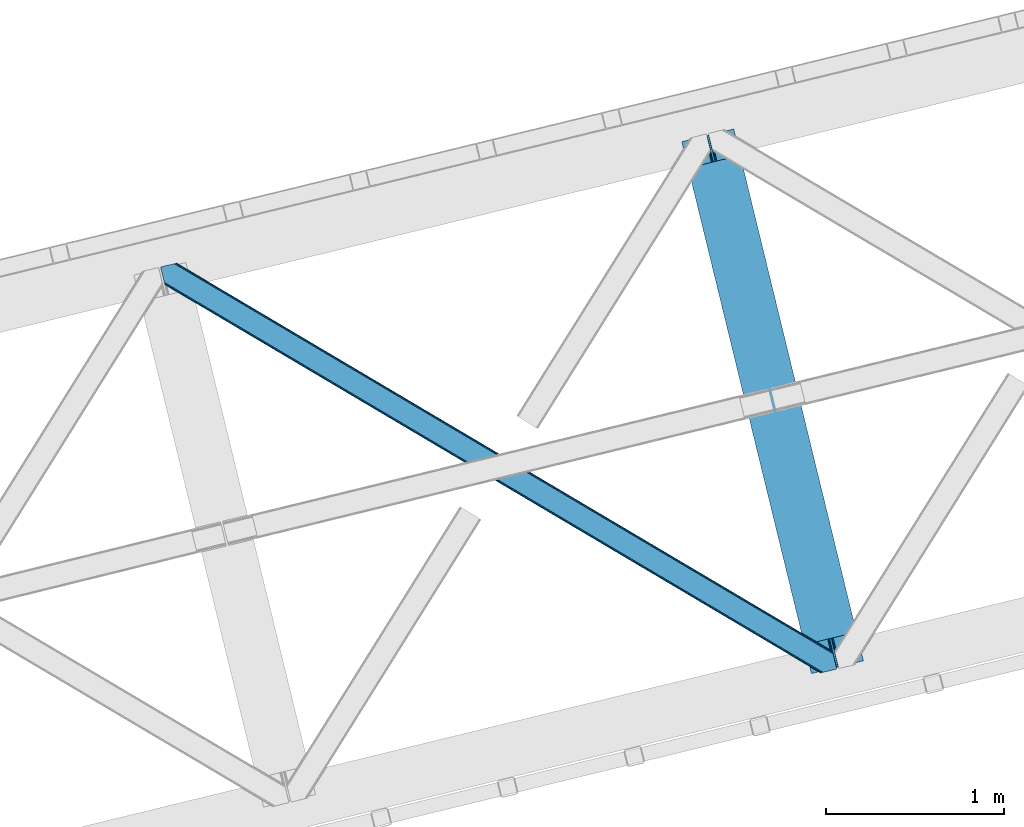
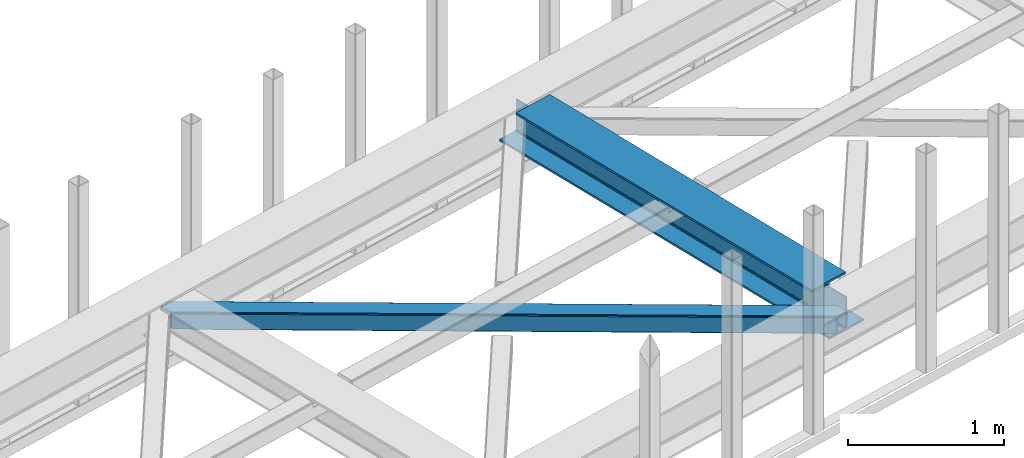
# One storey, part 41 of 67: 1 beam, 1 member.
"""IFC4 building model written with IfcOpenShell, lengths in millimetres."""

from ifc_helpers import new_model, entity, si_unit, converted_unit, derived_unit, direction, frame, origin, place, context, subcontext, project, spatial, triangles, polygons, material, type_object, element, save


model = new_model("IFC4")

# Units and contexts
model_context = context("Model", 3, precision=0.01, world=origin(), true_north=direction((6.12303176911189e-17, 1.0)))
plan_context = context("Plan", 3, precision=0.01, world=origin(), true_north=direction((6.12303176911189e-17, 1.0)))
body_context = subcontext(model_context, "Body", "Model", "MODEL_VIEW")
ifc_project = project(units=[si_unit("LENGTHUNIT", "METRE", prefix="MILLI"), si_unit("AREAUNIT", "SQUARE_METRE"), si_unit("VOLUMEUNIT", "CUBIC_METRE"), converted_unit("PLANEANGLEUNIT", "DEGREE", entity("IfcRatioMeasure", 0.0174532925199433), si_unit("PLANEANGLEUNIT", "RADIAN"), dimensions=[0, 0, 0, 0, 0, 0, 0]), si_unit("MASSUNIT", "GRAM", prefix="KILO"), derived_unit("MASSDENSITYUNIT", [(si_unit("MASSUNIT", "GRAM", prefix="KILO"), 1), (si_unit("LENGTHUNIT", "METRE"), -3)]), derived_unit("MOMENTOFINERTIAUNIT", [(si_unit("LENGTHUNIT", "METRE"), 4)]), si_unit("TIMEUNIT", "SECOND"), si_unit("FREQUENCYUNIT", "HERTZ"), si_unit("THERMODYNAMICTEMPERATUREUNIT", "DEGREE_CELSIUS"), derived_unit("THERMALTRANSMITTANCEUNIT", [(si_unit("MASSUNIT", "GRAM", prefix="KILO"), 1), (si_unit("THERMODYNAMICTEMPERATUREUNIT", "KELVIN"), -1), (si_unit("TIMEUNIT", "SECOND"), -3)]), derived_unit("VOLUMETRICFLOWRATEUNIT", [(si_unit("LENGTHUNIT", "METRE"), 3), (si_unit("TIMEUNIT", "SECOND"), -1)]), derived_unit("MASSFLOWRATEUNIT", [(si_unit("MASSUNIT", "GRAM", prefix="KILO"), 1), (si_unit("TIMEUNIT", "SECOND"), -1)]), derived_unit("ROTATIONALFREQUENCYUNIT", [(si_unit("TIMEUNIT", "SECOND"), -1)]), si_unit("ELECTRICCURRENTUNIT", "AMPERE"), si_unit("ELECTRICVOLTAGEUNIT", "VOLT"), si_unit("POWERUNIT", "WATT"), si_unit("FORCEUNIT", "NEWTON", prefix="KILO"), si_unit("ILLUMINANCEUNIT", "LUX"), si_unit("LUMINOUSFLUXUNIT", "LUMEN"), si_unit("LUMINOUSINTENSITYUNIT", "CANDELA"), derived_unit("USERDEFINED", [(si_unit("MASSUNIT", "GRAM", prefix="KILO"), -1), (si_unit("LENGTHUNIT", "METRE"), -2), (si_unit("TIMEUNIT", "SECOND"), 3), (si_unit("LUMINOUSFLUXUNIT", "LUMEN"), 1)]), derived_unit("LINEARVELOCITYUNIT", [(si_unit("LENGTHUNIT", "METRE"), 1), (si_unit("TIMEUNIT", "SECOND"), -1)]), si_unit("PRESSUREUNIT", "PASCAL"), derived_unit("USERDEFINED", [(si_unit("LENGTHUNIT", "METRE"), -2), (si_unit("MASSUNIT", "GRAM", prefix="KILO"), 1), (si_unit("TIMEUNIT", "SECOND"), -2)]), derived_unit("LINEARFORCEUNIT", [(si_unit("MASSUNIT", "GRAM", prefix="KILO"), 1), (si_unit("LENGTHUNIT", "METRE"), 1), (si_unit("TIMEUNIT", "SECOND"), -2), (si_unit("LENGTHUNIT", "METRE"), -1)]), derived_unit("PLANARFORCEUNIT", [(si_unit("MASSUNIT", "GRAM", prefix="KILO"), 1), (si_unit("LENGTHUNIT", "METRE"), 1), (si_unit("TIMEUNIT", "SECOND"), -2), (si_unit("LENGTHUNIT", "METRE"), -2)])], contexts=[model_context, plan_context])

# Site, building, storey
site_placement = place(None, origin())
site = spatial("IfcSite", under=ifc_project, at=site_placement, CompositionType="ELEMENT")
building_placement = place(site_placement, origin())
building = spatial("IfcBuilding", under=site, at=building_placement, CompositionType="ELEMENT")
storey_placement = place(building_placement, frame((0.0, 0.0, 19800.0)))
storey = spatial("IfcBuildingStorey", under=building, at=storey_placement, CompositionType="ELEMENT", Elevation=19800.0)

# Beam
ifc_material = material(Name="Metal painted (White)")
beam_type = type_object("IfcBeamType", PredefinedType="BEAM")
beam_placement = place(storey_placement, frame((-24164.8206423589, 11904.4985223094, 3807.02022389142)))
element("IfcBeam", 1, at=beam_placement, inside=storey, type_object=beam_type, material=ifc_material, ObjectType="Steel Beam", PredefinedType="BEAM", context=body_context, shape_type="Tessellation", body=[
    polygons([(1018.16648378329, 71.0478278971021, 15.5000000000008), (1018.16648378329, 71.0478278971, 0.0), (291.465617442446, 3052.25531830421, 0.0), (291.465617442446, 3052.25531830421, 15.5000000000008), (894.779372399325, 40.970914087327, 15.5000000000008), (168.078506058478, 3022.17840449444, 15.5000000000008), (888.087028625371, 39.3395844888221, 16.8701684147984), (161.38616228452, 3020.54707489593, 16.8701684147984), (882.413533524746, 37.9566100336519, 20.7720779386478), (155.712667183895, 3019.16410044076, 20.7720779386478), (878.622625296176, 37.0325360459184, 26.6116982174338), (151.921758955325, 3018.24002645303, 26.6116982174338), (877.291435352779, 36.7080444135007, 33.500000000001), (150.590569011932, 3017.91553482061, 33.500000000001), (140.875048430518, 3015.54727389071, 33.500000000001), (140.875048430514, 3015.54727389071, 259.000000000002), (150.590569011932, 3017.91553482061, 259.000000000002), (0.0, 2981.20749040711, 0.0), (4.33146851719357e-12, 2981.20749040711, 15.4999999999965), (123.387111383972, 3011.28440421689, 15.5000000000008), (130.079455157926, 3012.91573381539, 16.8701684147984), (135.752950258551, 3014.29870827056, 20.7720779386434), (139.543858487122, 3015.22278225829, 26.6116982174294), (877.291435352779, 36.7080444135007, 259.000000000002), (867.575914771365, 34.3397834835992, 259.000000000002), (867.575914771365, 34.3397834835992, 33.500000000001), (866.244724827968, 34.0152918511837, 26.6116982174294), (862.453816599397, 33.0912178634502, 20.7720779386434), (856.780321498777, 31.7082434082778, 16.8701684147984), (850.087977724819, 30.0769138097708, 15.5000000000008), (726.700866340851, 0.0, 15.4999999999965), (726.700866340851, 0.0, 0.0), (838.124523615916, 197.385937999183, 259.069791973884), (186.469722099967, 2870.72539801218, 259.000000000002), (186.69311520182, 2869.80895360721, 259.617303331124), (186.70550404545, 2869.75812937344, 266.500003008253), (837.979344808143, 197.981416001704, 266.500002998871), (837.979694928899, 197.97997969697, 260.000004007589), (828.499586345872, 194.645865944434, 259.006343171919), (828.276216326107, 195.562317481914, 259.617303331124), (828.263827482477, 195.613141715687, 266.500003008253), (176.98998671978, 2867.38985508742, 266.500002998871), (176.989636599032, 2867.39129139215, 260.000004007589), (176.844830940687, 2867.98534020594, 259.07612046749), (176.754201518552, 2868.35713708228, 259.000000000002), (839.31083267807, 198.30468544639, 273.388305639783), (843.101109266757, 199.231350618303, 279.227924098781), (848.774180214296, 200.616065081981, 283.129832400615), (855.46637189543, 202.248018612794, 284.500000377228), (978.853400583269, 232.325271667903, 284.500000138971), (978.851730776613, 232.332121736637, 299.999995328161), (687.386308679343, 161.283492472596, 299.999995890962), (687.387978485999, 161.276642403863, 284.500000701776), (810.775007173847, 191.353895458974, 284.500000463519), (817.467494069986, 192.984637925553, 283.129832461069), (823.141405718746, 194.365903570079, 279.227924137322), (826.932940505738, 195.287407219375, 273.388305663684), (175.658498849857, 2867.06658564273, 273.388305639788), (171.868222261165, 2866.13992047082, 279.227924098781), (166.195151313635, 2864.75520600714, 283.129832400619), (159.502959632502, 2863.12325247633, 284.500000377228), (36.1159309446533, 2833.04599942122, 284.500000138971), (36.1176007513094, 2833.03914935249, 299.999995328161), (327.58302284858, 2904.08777861653, 299.999995890962), (327.581353041924, 2904.09462868526, 284.500000701776), (204.194324354084, 2874.01737563015, 284.500000463519), (197.501837457945, 2872.38663316357, 283.129832461065), (191.827925809176, 2871.00536751904, 279.227924137322), (188.036391022189, 2870.08386386975, 273.388305663684)], [[[1, 2, 3, 4]], [[5, 1, 4, 6]], [[7, 5, 6, 8]], [[9, 7, 8, 10]], [[11, 9, 10, 12]], [[13, 11, 12, 14]], [[15, 16, 17, 14, 12, 10, 8, 6, 4, 3, 18, 19, 20, 21, 22, 23]], [[13, 24, 25, 26, 27, 28, 29, 30, 31, 32, 2, 1, 5, 7, 9, 11]], [[2, 32, 18, 3]], [[32, 31, 19, 18]], [[31, 30, 20, 19]], [[27, 26, 15, 23]], [[28, 27, 23, 22]], [[29, 28, 22, 21]], [[30, 29, 21, 20]], [[33, 24, 13, 14, 17, 34, 35, 36, 37, 38]], [[25, 39, 40, 41, 42, 43, 44, 16, 15, 26]], [[39, 25, 24, 33]], [[45, 34, 17, 16]], [[41, 40, 38, 37, 46, 47, 48, 49, 50, 51, 52, 53, 54, 55, 56, 57]], [[42, 58, 59, 60, 61, 62, 63, 64, 65, 66, 67, 68, 69, 36, 35, 43]], [[46, 37, 36, 69]], [[47, 46, 69, 68]], [[48, 47, 68, 67]], [[49, 48, 67, 66]], [[50, 49, 66, 65]], [[51, 50, 65, 64]], [[52, 51, 64, 63]], [[53, 52, 63, 62]], [[54, 53, 62, 61]], [[55, 54, 61, 60]], [[56, 55, 60, 59]], [[57, 56, 59, 58]], [[41, 57, 58, 42]]], closed=False),
])

# Member
member_type = type_object("IfcMemberType", PredefinedType="BRACE")
member_placement = place(storey_placement, frame((-27085.4955688477, 11907.5534088135, 3822.99993896484)))
element("IfcMember", 2, at=member_placement, inside=storey, type_object=member_type, ObjectType="Steel Horizontal Brace", PredefinedType="BRACE", context=body_context, shape_type="Tessellation", body=[
    triangles([(3167.12993774414, 476.930191040039, 17.5012573242202), (3764.84926757813, 123.064581298828, 122.499499511719), (3764.84926757813, 123.064581298828, 17.5012573242202), (2547.3375366211, 843.862445068358, 17.5012573242202), (1927.54513549805, 1210.79469909668, 17.5012573242202), (91.5037170410178, 2297.77602539063, 122.499499511719), (687.960333251955, 1944.65804443359, 17.5012573242202), (91.5037170410178, 2297.77602539063, 17.5012573242202), (1307.752734375, 1577.72579040527, 17.5012573242202), (3770.64193725586, 99.297427368163, 140.00075683594), (3768.42579345703, 108.393383789062, 138.668280029298), (76.4813781738303, 2294.11345825195, 138.668280029298), (67.1679931640647, 2291.8438293457, 140.00075683594), (3766.54683837891, 116.103378295898, 134.87548828125), (84.3762451171897, 2296.03775939941, 134.87548828125), (3765.29110107422, 121.255389404296, 129.196765136719), (89.6503417968779, 2297.32372741699, 129.196765136719), (3722.24256591797, 5.93103332519422, 140.00075683594), (18.7686218261733, 2198.47743530273, 140.00075683594), (3789.41055908203, 22.3044525146488, 140.00075683594), (0.0, 2275.47041015625, 140.00075683594), (3697.90916748047, 0.0, 122.499499511719), (3699.76254272461, 0.451135253906614, 129.196765136719), (24.1194580078154, 2176.5194732666, 129.196765136719), (24.5612915039092, 2174.71028137207, 122.499499511719), (3705.03431396485, 1.73710327148365, 134.87548828125), (22.8637207031279, 2181.671484375, 134.87548828125), (3712.92918090821, 3.66140441894458, 138.668280029298), (20.9847656250022, 2189.38147888184, 138.668280029298), (1862.08401489258, 1086.85342712402, 17.5012573242202), (2481.94152832031, 719.882803344726, 17.5012573242202), (3101.79904174805, 352.91217956543, 17.5012573242202), (3697.90916748047, 0.0, 17.5012573242202), (1242.22650146484, 1453.82405090332, 17.5012573242202), (622.371313476564, 1820.79467468262, 17.5012573242202), (24.5612915039092, 2174.71028137207, 17.5012573242202), (74.641955566407, 2293.66581115723, 127.873590087893), (66.7494140625022, 2291.74151000977, 131.668707275392), (79.9183776855498, 2294.9517791748, 122.197192382813), (57.4360290527366, 2289.47071838379, 133.001184082033), (0.0, 2275.47041015625, 133.001184082033), (81.7694274902351, 2295.40291442871, 115.499926757813), (81.7694274902351, 2295.40291442871, 24.5008300781265), (79.9183776855498, 2294.9517791748, 17.8035644531265), (89.5619750976584, 2297.30279846191, 10.8156188964858), (89.4712829589844, 2297.27954406738, 10.4993591308594), (74.1164062500029, 2293.53674926758, 12.4271484375022), (72.035137939456, 2293.0298034668, 10.4993591308594), (1922.19429931641, 1205.8275604248, 24.5008300781265), (3767.16540527344, 113.558184814452, 115.499926757813), (2545.11209106445, 837.045419311524, 24.5008300781265), (3168.02755737305, 468.263278198241, 24.5008300781265), (3767.16540527344, 113.558184814452, 24.5008300781265), (1299.27650756836, 1574.60853881836, 24.5008300781265), (676.361041259766, 1943.39067993164, 24.5008300781265), (3767.60723876953, 111.748992919922, 122.197192382813), (3768.86297607422, 106.596981811523, 127.873590087893), (3770.74193115234, 98.8858245849606, 131.668707275392), (3772.96040039063, 89.7910308837891, 133.001184082033), (3767.69560546875, 111.385061645507, 17.8686767578147), (3767.80490112305, 110.943228149414, 16.5199218750022), (3764.85856933594, 123.027374267578, 16.5199218750022), (3789.41055908203, 22.3044525146488, 133.001184082033), (3731.9745300293, 8.30298156738172, 133.001184082033), (16.4501586914084, 2207.98383178711, 133.001184082033), (162.736578369142, 2253.90428466797, 10.4993591308594), (166.88748779297, 2236.87509155273, 10.4993591308594), (3722.66347045899, 6.03451538085938, 131.668707275392), (18.6686279296882, 2198.88903808594, 131.668707275392), (3714.76860351563, 4.10905151367115, 127.873590087893), (20.547583007814, 2191.17788085938, 127.873590087893), (3709.49450683594, 2.82424621581958, 122.197192382813), (21.8033203125015, 2186.02586975098, 122.197192382813), (3707.64345703125, 2.3719482421875, 115.499926757813), (22.2451538085952, 2184.21667785644, 115.499926757813), (3114.18665771485, 353.712130737304, 24.5008300781265), (3707.64345703125, 2.3719482421875, 24.5008300781265), (2491.1200378418, 722.582638549804, 24.5008300781265), (1868.05341796875, 1091.4531463623, 24.5008300781265), (621.920178222659, 1829.19532470703, 24.5008300781265), (22.2451538085952, 2184.21667785644, 24.5008300781265), (1244.98679809571, 1460.32481689453, 24.5008300781265), (3709.49450683594, 2.82424621581958, 17.8035644531265), (3700.13461303711, 0.541827392577034, 10.8691040039084), (3700.58574829102, 0.652285766600471, 9.52034912109593), (3714.76860351563, 4.10905151367115, 12.1248413085959), (3719.39622802734, 5.23688964843677, 9.52034912109593), (21.7823913574248, 2186.11191101074, 17.817517089843), (21.7614624023445, 2186.20144042969, 17.5012573242202), (32.1375732421875, 2171.84650268555, 10.8179443359368), (28.3494323730483, 2188.73965759277, 10.4993591308594), (27.014630126956, 2187.35137023926, 12.1248413085959), (32.5003417968765, 2171.71046447754, 10.4993591308594), (203.966619873048, 2084.76809692383, 10.4993591308594), (208.117529296876, 2067.73890380859, 10.4993591308594), (164.09696044922, 2252.54739074707, 9.49942016601563), (168.582733154297, 2234.14386291504, 9.49942016601563), (168.166479492189, 2234.81707763672, 9.74591674804833), (163.771398925783, 2252.87527770996, 9.74126586914281), (167.736273193361, 2235.51005859375, 9.9993896484375), (163.417932128908, 2253.22525634766, 9.9993896484375), (167.306066894533, 2236.20187683105, 10.2528625488303), (163.066790771485, 2253.57639770508, 10.2598388671868), (209.161651611328, 2067.67146606445, 9.49942016601563), (209.136071777346, 2067.46682739258, 9.88311767578125), (204.680529785157, 2085.44247436523, 9.8528869628899), (208.803533935548, 2067.5551940918, 10.0831054687515), (204.685180664063, 2084.81111755371, 10.2063537597678), (208.450067138674, 2067.65053710938, 10.2993713378928), (204.324737548828, 2084.78902587891, 10.3528564453118), (204.675878906251, 2086.07383117676, 9.49942016601563), (3763.57725219727, 109.725860595703, 12.1248413085959), (3758.56825561524, 124.970278930663, 10.8714294433594), (3757.06602172852, 125.435366821288, 9.52034912109593), (3761.54481811524, 107.063232421875, 9.52034912109593), (3585.92530517578, 211.033630371094, 9.52034912109593), (3581.44650878906, 229.405764770507, 9.52034912109593), (3585.50672607422, 211.133624267577, 9.44360961914208), (3581.04885864258, 229.553430175782, 9.37384643554833), (3580.64888305664, 229.701095581055, 9.22734375000073), (3580.53726196289, 229.532501220703, 8.87387695312646), (3585.4578918457, 210.476687622069, 9.13897705078125), (3580.42796630859, 229.365069580077, 8.52041015625218), (3585.40673217774, 209.805798339843, 8.82736816406396), (3585.35557250977, 209.14769897461, 8.52041015625218), (3164.51614379883, 472.51883239746, 5.12526855468968), (3581.30465698242, 225.771102905273, 5.12526855468968), (3166.44858398438, 475.783749389648, 10.8039916992202), (687.281304931643, 1943.5116027832, 10.8039916992202), (685.348864746094, 1940.24784851074, 5.12526855468968), (165.152709960938, 2248.2150970459, 5.12526855468968), (682.456018066408, 1935.36210021973, 1.33247680664135), (167.031665039063, 2240.50510253906, 1.33247680664135), (679.044598388675, 1929.59966125488, 0.0), (169.250134277347, 2231.40914611816, 0.0), (3583.18361206055, 218.061108398437, 1.33247680664135), (3585.39975585938, 208.965151977538, 0.0), (3158.21187744141, 461.870645141602, 0.0), (3161.6256225586, 467.634246826172, 1.33247680664135), (2546.65618286133, 842.716003417969, 10.8039916992202), (1926.86610717774, 1209.64825744629, 10.8039916992202), (1307.07370605469, 1576.58051147461, 10.8039916992202), (2544.72606811524, 839.452249145508, 5.12526855468968), (1924.93366699219, 1206.3833404541, 5.12526855468968), (1305.14126586914, 1573.31559448242, 5.12526855468968), (2541.83322143555, 834.566500854491, 1.33247680664135), (1922.0408203125, 1201.49875488281, 1.33247680664135), (1302.24841918945, 1568.42984619141, 1.33247680664135), (2538.41947631836, 828.802899169921, 0.0), (1918.62940063477, 1195.73515319824, 0.0), (1298.83699951172, 1562.66740722656, 0.0), (3620.16042480469, 66.3657165527347, 0.0), (3110.71245117188, 367.97056274414, 0.0), (2490.85493774414, 734.941186523438, 0.0), (1870.99974975586, 1101.91181030273, 0.0), (631.284722900393, 1835.85305786133, 0.0), (1251.14223632813, 1468.88243408203, 0.0), (204.010803222656, 2088.80854797363, 0.0), (3167.34852905274, 467.116836547852, 17.8035644531265), (3165.41608886719, 463.851919555664, 12.1248413085959), (673.749572753906, 1938.98048400879, 12.1248413085959), (675.682012939455, 1942.24423828125, 17.8035644531265), (670.85672607422, 1934.09473571777, 8.3320495605476), (169.398962402345, 2230.80104370117, 8.81806640624927), (171.566271972657, 2221.90274963379, 6.99957275390625), (3159.11182250977, 453.203732299804, 6.99957275390625), (3587.71821899414, 199.458755493164, 6.99957275390625), (3585.50905151367, 208.524481201172, 8.42274169921802), (3162.5232421875, 458.967333984374, 8.3320495605476), (667.445306396487, 1928.33229675293, 6.99957275390625), (2539.60777587891, 827.749475097657, 8.3320495605476), (2536.19403076172, 821.985873413085, 6.99957275390625), (1916.68998413086, 1196.53161621094, 8.3320495605476), (1913.27856445313, 1190.76801452637, 6.99957275390625), (1293.77451782227, 1565.31259460449, 8.3320495605476), (1290.36077270508, 1559.55015563965, 6.99957275390625), (2542.49829711914, 832.634060668945, 12.1248413085959), (1919.58283081055, 1201.41620178223, 12.1248413085959), (1296.66736450195, 1570.19834289551, 12.1248413085959), (2544.43073730469, 835.898977661132, 17.8035644531265), (1921.51294555664, 1204.67995605469, 17.8035644531265), (1298.5998046875, 1573.46325988769, 17.8035644531265), (201.692340087891, 2098.31610717773, 6.99957275390625), (203.861975097658, 2089.41665039063, 8.81806640624927), (206.226947021485, 2079.71375427246, 1.33247680664135), (208.105902099611, 2072.00375976562, 5.12526855468968), (2500.03577270508, 737.642184448241, 6.99957275390625), (3123.10239257813, 368.771676635743, 6.99957275390625), (1876.96915283203, 1106.51269226074, 6.99957275390625), (3617.84428710938, 75.8721130371086, 6.99957275390625), (630.835913085939, 1844.25487060547, 6.99957275390625), (1253.90253295899, 1475.38320007324, 6.99957275390625), (3119.68864746094, 363.008074951171, 8.3320495605476), (3620.56272583008, 65.0402160644535, 8.90410766601781), (3620.2046081543, 66.183169555663, 8.52041015625218), (3116.7981262207, 358.123489379883, 12.1248413085959), (3621.05339355469, 64.3216552734375, 9.1087463378899), (3621.55103759766, 63.5914672851559, 9.31571044922021), (3622.04170532227, 62.8729064941399, 9.52034912109593), (3620.05345458984, 66.8063873291012, 8.42274169921802), (624.529321289065, 1833.60552062988, 12.1248413085959), (627.422167968751, 1838.4912689209, 8.3320495605476), (622.596881103516, 1830.34176635742, 17.8035644531265), (3114.86568603516, 354.858572387695, 17.8035644531265), (2491.79906616211, 723.729080200195, 17.8035644531265), (1868.73244628906, 1092.60075073242, 17.8035644531265), (1245.66582641602, 1461.47125854492, 17.8035644531265), (2493.73150634766, 726.993997192383, 12.1248413085959), (1870.66256103516, 1095.86450500488, 12.1248413085959), (1247.59826660156, 1464.73501281738, 12.1248413085959), (2496.62435302735, 731.879745483398, 8.3320495605476), (1873.55540771484, 1100.7502532959, 8.3320495605476), (1250.49111328125, 1469.6207611084, 8.3320495605476), (3102.47574462891, 354.057458496094, 10.8039916992202), (624.980456542969, 1825.20487060547, 5.12526855468968), (623.048016357425, 1821.94111633301, 10.8039916992202), (3626.52050170899, 44.5007720947269, 9.52034912109593), (3104.40818481446, 357.32237548828, 5.12526855468968), (3624.2578491211, 49.5597656249993, 5.12526855468968), (3625.13453979492, 45.9657989501957, 8.52041015625218), (3625.82752075195, 45.2332855224613, 9.02037963867406), (3622.37889404297, 57.2697601318359, 1.33247680664135), (3107.30103149414, 362.208123779297, 1.33247680664135), (627.873303222659, 1830.09061889648, 1.33247680664135), (2487.44351806641, 729.178747558593, 1.33247680664135), (1867.58833007813, 1096.14937133789, 1.33247680664135), (1247.73081665039, 1463.11999511719, 1.33247680664135), (2484.55299682617, 724.292999267578, 5.12526855468968), (1864.69548339844, 1091.26362304687, 5.12526855468968), (1244.8379699707, 1458.23424682617, 5.12526855468968), (2482.61823120117, 721.02808227539, 10.8039916992202), (1862.76304321289, 1087.99870605469, 10.8039916992202), (1242.90552978516, 1454.96932983398, 10.8039916992202)], [[1, 2, 3], [2, 1, 4], [2, 5, 6], [5, 2, 4], [7, 8, 6], [9, 6, 5], [6, 9, 7], [10, 11, 12], [12, 13, 10], [11, 14, 15], [15, 12, 11], [14, 16, 17], [17, 15, 14], [16, 2, 6], [6, 17, 16], [18, 10, 19], [18, 20, 10], [13, 19, 10], [21, 19, 13], [22, 23, 24], [24, 25, 22], [23, 26, 27], [27, 24, 23], [26, 28, 29], [29, 27, 26], [28, 18, 19], [19, 29, 28], [30, 22, 25], [22, 31, 32], [30, 31, 22], [32, 33, 22], [34, 25, 35], [25, 34, 30], [36, 35, 25], [37, 38, 12], [15, 37, 12], [15, 17, 39], [37, 15, 39], [39, 17, 6], [38, 13, 12], [21, 40, 41], [21, 13, 40], [38, 40, 13], [39, 6, 42], [43, 8, 44], [6, 43, 42], [8, 45, 44], [6, 8, 43], [46, 44, 45], [46, 47, 44], [46, 48, 47], [49, 50, 42], [50, 51, 52], [49, 51, 50], [52, 53, 50], [54, 42, 55], [42, 54, 49], [43, 55, 42], [50, 56, 42], [39, 42, 56], [56, 57, 39], [37, 39, 57], [57, 58, 37], [38, 37, 58], [58, 59, 38], [40, 38, 59], [57, 14, 11], [59, 58, 10], [58, 57, 11], [60, 61, 62], [63, 59, 20], [10, 20, 59], [58, 11, 10], [60, 3, 53], [2, 50, 53], [53, 3, 2], [60, 62, 3], [2, 56, 50], [56, 14, 57], [14, 56, 16], [2, 16, 56], [59, 64, 65], [64, 59, 63], [65, 40, 59], [41, 40, 65], [66, 67, 46], [48, 46, 67], [64, 68, 65], [69, 65, 68], [68, 70, 69], [71, 69, 70], [70, 72, 71], [73, 71, 72], [72, 74, 73], [75, 73, 74], [76, 74, 77], [74, 76, 78], [74, 79, 75], [79, 74, 78], [80, 81, 75], [82, 75, 79], [75, 82, 80], [70, 68, 28], [26, 70, 28], [26, 23, 72], [70, 26, 72], [72, 23, 22], [68, 18, 28], [20, 64, 63], [20, 18, 64], [68, 64, 18], [72, 22, 74], [77, 33, 83], [22, 77, 74], [33, 84, 83], [22, 33, 77], [85, 83, 84], [86, 83, 85], [87, 86, 85], [73, 75, 25], [25, 24, 73], [27, 73, 24], [73, 27, 71], [25, 81, 36], [88, 89, 36], [36, 81, 88], [75, 81, 25], [69, 29, 19], [21, 65, 19], [41, 65, 21], [69, 71, 29], [29, 71, 27], [65, 69, 19], [90, 91, 92], [90, 93, 91], [92, 36, 90], [89, 36, 92], [94, 95, 93], [93, 91, 94], [96, 97, 98], [98, 99, 96], [99, 98, 100], [100, 101, 99], [101, 100, 102], [102, 103, 101], [103, 102, 67], [67, 66, 103], [104, 105, 106], [105, 107, 108], [108, 107, 109], [110, 109, 95], [95, 94, 110], [109, 110, 108], [108, 106, 105], [106, 111, 104], [62, 112, 113], [112, 62, 61], [112, 114, 113], [112, 115, 114], [114, 115, 116], [116, 117, 114], [118, 119, 117], [120, 119, 118], [121, 120, 122], [123, 121, 124], [124, 125, 123], [122, 124, 121], [118, 122, 120], [117, 116, 118], [1, 3, 113], [3, 62, 113], [120, 121, 126], [123, 126, 121], [123, 127, 126], [128, 113, 117], [117, 126, 128], [117, 119, 126], [120, 126, 119], [113, 114, 117], [45, 129, 66], [129, 130, 131], [131, 96, 129], [129, 99, 101], [99, 129, 96], [129, 103, 66], [103, 129, 101], [129, 45, 8], [8, 7, 129], [66, 46, 45], [130, 132, 133], [133, 131, 130], [132, 134, 135], [135, 133, 132], [136, 137, 138], [138, 139, 136], [127, 136, 139], [139, 126, 127], [113, 128, 1], [1, 128, 140], [140, 4, 1], [4, 140, 141], [141, 5, 4], [5, 141, 142], [142, 9, 5], [9, 142, 129], [129, 7, 9], [128, 126, 143], [143, 140, 128], [140, 143, 141], [144, 141, 143], [141, 144, 142], [145, 142, 144], [142, 145, 129], [130, 129, 145], [126, 139, 146], [146, 143, 126], [143, 146, 147], [147, 144, 143], [144, 147, 148], [148, 145, 144], [145, 148, 132], [132, 130, 145], [139, 138, 146], [149, 146, 138], [146, 149, 147], [150, 147, 149], [147, 150, 148], [151, 148, 150], [148, 151, 132], [134, 132, 151], [137, 152, 153], [138, 153, 154], [153, 138, 137], [149, 155, 150], [154, 149, 138], [149, 154, 155], [156, 134, 151], [150, 157, 151], [157, 150, 155], [157, 156, 151], [158, 134, 156], [135, 134, 158], [159, 160, 112], [112, 61, 159], [159, 60, 53], [161, 162, 44], [98, 163, 100], [98, 97, 163], [163, 102, 100], [163, 67, 102], [97, 164, 163], [161, 47, 67], [67, 163, 161], [47, 48, 67], [163, 164, 165], [166, 167, 168], [160, 118, 116], [116, 112, 160], [116, 115, 112], [169, 168, 125], [125, 160, 169], [124, 122, 160], [122, 118, 160], [160, 125, 124], [168, 169, 166], [165, 170, 163], [44, 47, 161], [162, 55, 43], [43, 44, 162], [53, 52, 159], [61, 60, 159], [166, 169, 171], [171, 172, 166], [172, 171, 173], [173, 174, 172], [174, 173, 175], [175, 176, 174], [176, 175, 163], [163, 170, 176], [169, 160, 171], [177, 171, 160], [171, 177, 173], [178, 173, 177], [173, 178, 175], [179, 175, 178], [175, 179, 163], [161, 163, 179], [160, 159, 180], [180, 177, 160], [177, 180, 181], [181, 178, 177], [178, 181, 182], [182, 179, 178], [179, 182, 162], [162, 161, 179], [159, 52, 180], [51, 180, 52], [180, 51, 49], [49, 181, 180], [181, 49, 54], [54, 182, 181], [182, 54, 162], [55, 162, 54], [97, 131, 133], [135, 97, 133], [165, 164, 135], [165, 135, 183], [131, 97, 96], [135, 164, 97], [183, 158, 184], [158, 185, 111], [158, 183, 135], [186, 111, 185], [158, 111, 184], [186, 104, 111], [187, 188, 166], [166, 172, 187], [172, 189, 187], [189, 172, 174], [188, 167, 166], [188, 190, 167], [170, 191, 176], [191, 170, 183], [165, 183, 170], [192, 176, 191], [174, 192, 189], [176, 192, 174], [193, 194, 195], [196, 197, 194], [196, 198, 197], [196, 199, 198], [194, 193, 196], [195, 200, 193], [86, 87, 199], [199, 196, 86], [193, 200, 190], [191, 183, 184], [201, 108, 110], [110, 94, 201], [94, 92, 201], [94, 91, 92], [202, 106, 108], [202, 111, 106], [202, 184, 111], [108, 201, 202], [203, 201, 92], [92, 89, 203], [203, 88, 81], [81, 80, 203], [89, 88, 203], [184, 202, 191], [190, 188, 193], [83, 86, 196], [196, 204, 83], [77, 83, 204], [204, 76, 77], [76, 204, 205], [205, 78, 76], [78, 205, 206], [206, 79, 78], [79, 206, 207], [207, 82, 79], [82, 207, 80], [203, 80, 207], [204, 196, 205], [208, 205, 196], [205, 208, 206], [209, 206, 208], [206, 209, 207], [210, 207, 209], [207, 210, 201], [201, 203, 207], [196, 193, 211], [211, 208, 196], [208, 211, 212], [212, 209, 208], [209, 212, 213], [213, 210, 209], [210, 213, 202], [202, 201, 210], [193, 188, 211], [187, 211, 188], [211, 187, 212], [189, 212, 187], [212, 189, 213], [192, 213, 189], [213, 192, 191], [191, 202, 213], [214, 84, 33], [35, 36, 90], [215, 105, 104], [216, 90, 95], [95, 215, 216], [95, 107, 215], [104, 186, 215], [84, 214, 217], [214, 218, 219], [219, 220, 214], [221, 217, 214], [214, 220, 221], [217, 85, 84], [222, 219, 218], [218, 223, 222], [152, 222, 223], [223, 153, 152], [156, 224, 185], [185, 158, 156], [224, 215, 186], [186, 185, 224], [90, 216, 35], [33, 32, 214], [153, 223, 154], [225, 154, 223], [154, 225, 155], [226, 155, 225], [155, 226, 157], [227, 157, 226], [157, 227, 224], [224, 156, 157], [223, 218, 228], [228, 225, 223], [225, 228, 229], [229, 226, 225], [226, 229, 230], [230, 227, 226], [227, 230, 224], [215, 224, 230], [218, 214, 231], [231, 228, 218], [228, 231, 229], [232, 229, 231], [229, 232, 230], [233, 230, 232], [230, 233, 216], [216, 215, 230], [214, 32, 31], [31, 231, 214], [231, 31, 30], [30, 232, 231], [232, 30, 34], [34, 233, 232], [233, 34, 216], [35, 216, 34], [137, 167, 190], [125, 127, 123], [137, 125, 167], [125, 136, 127], [125, 137, 136], [152, 137, 190], [195, 152, 190], [219, 195, 220], [195, 222, 152], [195, 219, 222], [220, 195, 194], [221, 194, 197], [221, 197, 198], [217, 198, 199], [87, 85, 199], [217, 199, 85]]),
])

save(model, "model.ifc")
